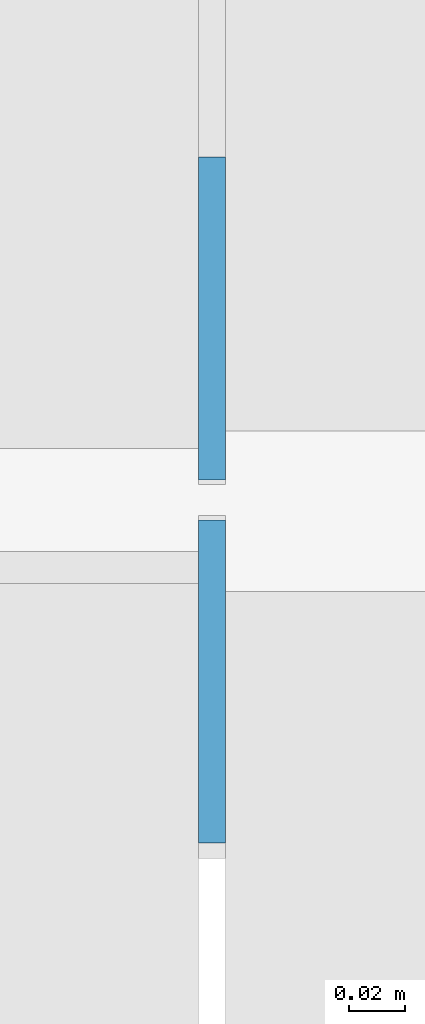
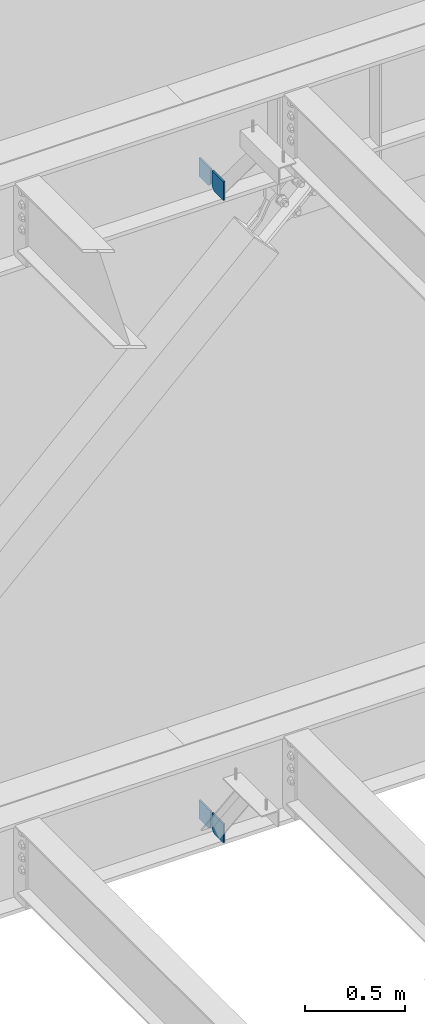
# One storey, part 577 of 1179: 4 columns, 2 elements without a shape of their own.
"""IFC2X3 building model written with IfcOpenShell, lengths in millimetres."""

import ifcopenshell
import ifcopenshell.guid

model = None  # the IFC model being written
_history = None  # IfcOwnerHistory: only IFC2X3 demands one
_inside = {}  # id of a spatial element -> (the spatial element, [elements in it])
_under = {}  # id of a project, library or spatial element -> (it, [spatial elements below it])
_declared = {}  # id of a project -> (the project, [libraries it declares])
_typed = {}  # id of a type object -> (the type object, [elements of that type])
_made_of = {}  # id of a material, layer set ... -> (it, [elements and type objects made of it])


def new_model(schema):
    """Start an empty IFC model of exactly this schema.

    Asked for "IFC4X3", IfcOpenShell would pick the latest addendum, in which some entities
    have other attributes; the version numbers below select the first issue.
    IFC2X3 requires an IfcOwnerHistory on every rooted entity: one is made here for all.
    """
    global model, _history
    if schema == "IFC4X3":
        model = ifcopenshell.file(schema_version=(4, 3, 0, 0))
    else:
        model = ifcopenshell.file(schema=schema)
    _inside.clear()
    _under.clear()
    _declared.clear()
    _typed.clear()
    _made_of.clear()
    _history = None
    if model.schema == "IFC2X3":
        org = make("IfcOrganization", Name="unknown")
        user = make(
            "IfcPersonAndOrganization",
            ThePerson=make("IfcPerson", FamilyName="unknown"),
            TheOrganization=org,
        )
        app = make(
            "IfcApplication",
            ApplicationDeveloper=org,
            Version="unknown",
            ApplicationFullName="unknown",
            ApplicationIdentifier="unknown",
        )
        _history = make(
            "IfcOwnerHistory",
            OwningUser=user,
            OwningApplication=app,
            ChangeAction="ADDED",
            CreationDate=0,
        )
    return model


def make(cls, **values):
    """One entity of the class cls with the attributes given. An attribute that is None is left unset."""
    return model.create_entity(
        cls, **{name: value for name, value in values.items() if value is not None}
    )


def rooted(cls, **values):
    """An entity with a GlobalId (a new one), such as an element, a storey or a relation."""
    return make(cls, GlobalId=ifcopenshell.guid.new(), OwnerHistory=_history, **values)


def si_unit(unit_type, name, prefix=None):
    """IfcSIUnit, for example si_unit("LENGTHUNIT", "METRE", prefix="MILLI")."""
    return make("IfcSIUnit", UnitType=unit_type, Prefix=prefix, Name=name)


def assignment(units):
    """IfcUnitAssignment: the units of a project."""
    return None if units is None else make("IfcUnitAssignment", Units=units)


def point(xyz):
    """IfcCartesianPoint."""
    return None if xyz is None else make("IfcCartesianPoint", Coordinates=xyz)


def direction(xyz):
    """IfcDirection."""
    return None if xyz is None else make("IfcDirection", DirectionRatios=xyz)


def frame(location, z_axis=None, x_axis=None):
    """IfcAxis2Placement3D, a coordinate frame: its origin and axes. An axis left out is left unset."""
    return make(
        "IfcAxis2Placement3D",
        Location=point(location),
        Axis=direction(z_axis),
        RefDirection=direction(x_axis),
    )


def origin_with_axes():
    """The frame at (0, 0, 0) with the z axis (0, 0, 1) and the x axis (1, 0, 0) written out."""
    return frame((0.0, 0.0, 0.0), z_axis=(0.0, 0.0, 1.0), x_axis=(1.0, 0.0, 0.0))


def place(relative_to, where):
    """IfcLocalPlacement: puts the frame where relative to a parent placement (None: the world)."""
    return make(
        "IfcLocalPlacement", PlacementRelTo=relative_to, RelativePlacement=where
    )


def context(
    kind, dimensions, precision=None, world=None, true_north=None, identifier=None
):
    """IfcGeometricRepresentationContext, for example the 3D "Model" context."""
    return make(
        "IfcGeometricRepresentationContext",
        ContextIdentifier=identifier,
        ContextType=kind,
        CoordinateSpaceDimension=dimensions,
        Precision=precision,
        WorldCoordinateSystem=world,
        TrueNorth=true_north,
    )


def subcontext(parent, identifier, kind, view, scale=None):
    """IfcGeometricRepresentationSubContext, for example "Body" below "Model"."""
    return make(
        "IfcGeometricRepresentationSubContext",
        ContextIdentifier=identifier,
        ContextType=kind,
        ParentContext=parent,
        TargetScale=scale,
        TargetView=view,
    )


def project(units=None, contexts=None):
    """IfcProject with its units and contexts."""
    return rooted(
        "IfcProject",
        Name="project",
        RepresentationContexts=contexts,
        UnitsInContext=assignment(units),
    )


def spatial(cls, under=None, at=None, **own):
    """A site, building, storey or space (cls), placed at a placement, below another one or the project."""
    s = rooted(cls, ObjectPlacement=at, **own)
    if under is not None:
        _under.setdefault(under.id(), (under, []))[1].append(s)
    return s


def faces_of(points, faces, orient=None, outer=None):
    """IfcFace entities. A face is a list of loops; a loop is a list of indices into points, from 0.

    orient and outer hold one flag for each loop. By default every Orientation is true, the
    first loop of a face is its IfcFaceOuterBound and the others are IfcFaceBound.
    """
    made = []
    for i, loops in enumerate(faces):
        bounds = []
        for j, loop in enumerate(loops):
            is_outer = j == 0 if outer is None else outer[i][j]
            bounds.append(
                make(
                    "IfcFaceOuterBound" if is_outer else "IfcFaceBound",
                    Bound=make("IfcPolyLoop", Polygon=[points[k] for k in loop]),
                    Orientation=True if orient is None else orient[i][j],
                )
            )
        made.append(make("IfcFace", Bounds=bounds))
    return made


def faceted_brep(points, faces, orient=None, outer=None, voids=None):
    """IfcFacetedBrep: a solid bounded by flat faces; with voids (closed shells), ...WithVoids."""
    shared = [point(p) for p in points]
    hull = make("IfcClosedShell", CfsFaces=faces_of(shared, faces, orient, outer))
    if voids is None:
        return make("IfcFacetedBrep", Outer=hull)
    return make(
        "IfcFacetedBrepWithVoids",
        Outer=hull,
        Voids=[
            make(cls, CfsFaces=faces_of(shared, fs, o, b)) for cls, fs, o, b in voids
        ],
    )


def shape(context_of_items, identifier, shape_type, items):
    """IfcShapeRepresentation: the items that make up one representation, for example the "Body"."""
    return make(
        "IfcShapeRepresentation",
        ContextOfItems=context_of_items,
        RepresentationIdentifier=identifier,
        RepresentationType=shape_type,
        Items=items,
    )


def material(Name=None, Category=None):
    """IfcMaterial."""
    return make("IfcMaterial", Name=Name, Category=Category)


def made_of(thing, what):
    """Note that an element or type object is made of a material, layer set ...; save() writes the relation."""
    if what is not None:
        _made_of.setdefault(what.id(), (what, []))[1].append(thing)
    return thing


def type_object(cls, material=None, **own):
    """A type object (cls), such as IfcWallType, which elements share."""
    return made_of(rooted(cls, **own), material)


def element(
    cls,
    number,
    at=None,
    inside=None,
    cuts=None,
    type_object=None,
    material=None,
    context=None,
    identifier="Body",
    shape_type=None,
    held_by="IfcProductDefinitionShape",
    body=None,
    shapes=None,
    **own,
):
    """One element of the class cls, such as IfcWall. Its Tag is "e" and its number.

    at: its placement. inside: the storey or other place that contains it. cuts: it is an
    opening in that element (IfcRelVoidsElement). A single representation is given by context,
    identifier, shape_type and body (its items); several are given by shapes. held_by: the class
    of the entity that holds the representations. save() writes the other relations.
    """
    e = rooted(cls, Tag="e%d" % number, ObjectPlacement=at, **own)
    if body is not None:
        shapes = [shape(context, identifier, shape_type, body)]
    if shapes is not None:
        e.Representation = make(held_by, Representations=shapes)
    if inside is not None:
        _inside.setdefault(inside.id(), (inside, []))[1].append(e)
    if cuts is not None:
        rooted(
            "IfcRelVoidsElement", RelatingBuildingElement=cuts, RelatedOpeningElement=e
        )
    if type_object is not None:
        _typed.setdefault(type_object.id(), (type_object, []))[1].append(e)
    return made_of(e, material)


def aggregate(whole, parts):
    """IfcRelAggregates: a whole, such as a stair, and the parts it consists of."""
    return rooted("IfcRelAggregates", RelatingObject=whole, RelatedObjects=parts)


def save(model, path):
    """Write the relations noted so far, then the file.

    IfcRelAggregates (storeys below a building ...), IfcRelContainedInSpatialStructure (elements
    in a storey), IfcRelDefinesByType, IfcRelAssociatesMaterial and IfcRelDeclares: one each for
    every whole, place, type object, material and project.
    """
    for whole, parts in _under.values():
        aggregate(whole, parts)
    for where, things in _inside.values():
        rooted(
            "IfcRelContainedInSpatialStructure",
            RelatedElements=things,
            RelatingStructure=where,
        )
    for kind, things in _typed.values():
        rooted("IfcRelDefinesByType", RelatedObjects=things, RelatingType=kind)
    for what, things in _made_of.values():
        rooted("IfcRelAssociatesMaterial", RelatedObjects=things, RelatingMaterial=what)
    for by, libraries in _declared.values():
        rooted("IfcRelDeclares", RelatingContext=by, RelatedDefinitions=libraries)
    model.write(path)


model = new_model("IFC2X3")

# Units and contexts
model_context = context("Model", 3, precision=1e-05, world=origin_with_axes())
body_context = subcontext(model_context, "Body", "Model", "MODEL_VIEW")
ifc_project = project(units=[si_unit("LENGTHUNIT", "METRE", prefix="MILLI"), si_unit("AREAUNIT", "SQUARE_METRE"), si_unit("VOLUMEUNIT", "CUBIC_METRE"), si_unit("MASSUNIT", "GRAM", prefix="KILO"), si_unit("TIMEUNIT", "SECOND"), si_unit("PLANEANGLEUNIT", "RADIAN"), si_unit("SOLIDANGLEUNIT", "STERADIAN"), si_unit("THERMODYNAMICTEMPERATUREUNIT", "DEGREE_CELSIUS"), si_unit("LUMINOUSINTENSITYUNIT", "LUMEN")], contexts=[model_context])

# Site, building, storey
site_placement = place(None, origin_with_axes())
site = spatial("IfcSite", under=ifc_project, at=site_placement, CompositionType="ELEMENT")
building_placement = place(site_placement, origin_with_axes())
building = spatial("IfcBuilding", under=site, at=building_placement, Name="Undefined", CompositionType="ELEMENT")
storey_placement = place(building_placement, origin_with_axes())
storey = spatial("IfcBuildingStorey", under=building, at=storey_placement, Name="Undefined", CompositionType="ELEMENT", Elevation=0.0)

# Assembly, columns
assembly_1_placement = place(storey_placement, origin_with_axes())
assembly_1 = element("IfcElementAssembly", 1, at=assembly_1_placement, inside=storey, Name="BEAM", AssemblyPlace="NOTDEFINED", PredefinedType="RIGID_FRAME")
ifc_material = material(Name="STEEL/A36")
column_type = type_object("IfcColumnType", PredefinedType="NOTDEFINED")
column_1_placement = place(assembly_1_placement, frame((11460.1625, 41263.09375, 7488.2375), z_axis=(0.0, -1.0, 0.0), x_axis=(0.0, 0.0, 1.0)))
column_1 = element("IfcColumn", 2, at=column_1_placement, type_object=column_type, material=ifc_material, Name="PLATE", context=body_context, shape_type="Brep", body=[
    faceted_brep([(22.2250000000004, 4.76250000000073, 57.1500000000015), (0.0, 4.76250000000073, 34.9249999999993), (0.0, -4.76250000000073, 34.9249999999993), (22.2250000000004, -4.76250000000073, 57.1500000000015), (114.300000000001, 4.76250000000073, 57.1500000000015), (114.300000000001, 4.76250000000073, -57.1500000000015), (0.0, 4.76250000000073, -57.1500000000015), (114.300000000001, -4.76250000000073, 57.1500000000015), (0.0, -4.76250000000073, -57.1500000000015), (114.300000000001, -4.76250000000073, -57.1500000000015)], [[[0, 1, 2, 3]], [[4, 5, 6, 1, 0]], [[7, 4, 0, 3]], [[8, 9, 7, 3, 2]], [[8, 6, 5, 9]], [[7, 9, 5, 4]], [[6, 8, 2, 1]]]),
])
column_2_placement = place(assembly_1_placement, frame((11460.1625, 41134.50625, 7488.2375), z_axis=(0.0, 1.0, 0.0), x_axis=(0.0, 0.0, 1.0)))
column_2 = element("IfcColumn", 3, at=column_2_placement, type_object=column_type, material=ifc_material, Name="PLATE", context=body_context, shape_type="Brep", body=[
    faceted_brep([(22.2250000000004, 4.76250000000073, 57.1500000000015), (0.0, 4.76250000000073, 34.9249999999993), (0.0, -4.76250000000073, 34.9249999999993), (22.2250000000004, -4.76250000000073, 57.1500000000015), (114.300000000001, 4.76250000000073, 57.1500000000015), (114.300000000001, 4.76250000000073, -57.1500000000015), (0.0, 4.76250000000073, -57.1500000000015), (114.300000000001, -4.76250000000073, 57.1500000000015), (0.0, -4.76250000000073, -57.1500000000015), (114.300000000001, -4.76250000000073, -57.1500000000015)], [[[0, 1, 2, 3]], [[4, 5, 6, 1, 0]], [[7, 4, 0, 3]], [[8, 9, 7, 3, 2]], [[8, 6, 5, 9]], [[7, 9, 5, 4]], [[6, 8, 2, 1]]]),
])
aggregate(assembly_1, [column_1, column_2])

assembly_2_placement = place(storey_placement, origin_with_axes())
assembly_2 = element("IfcElementAssembly", 4, at=assembly_2_placement, inside=storey, Name="BEAM", AssemblyPlace="NOTDEFINED", PredefinedType="RIGID_FRAME")
column_3_placement = place(assembly_2_placement, frame((11460.16275, 41263.093625, 3576.6375), z_axis=(0.0, -1.0, 0.0), x_axis=(0.0, 0.0, 1.0)))
column_3 = element("IfcColumn", 5, at=column_3_placement, type_object=column_type, material=ifc_material, Name="PLATE", context=body_context, shape_type="Brep", body=[
    faceted_brep([(19.0500000000002, 4.76250000000073, 57.1500000000015), (0.0, 4.76250000000073, 38.0999999999985), (0.0, -4.76250000000073, 38.0999999999985), (19.0500000000002, -4.76250000000073, 57.1500000000015), (114.300000000001, 4.76250000000073, 57.1500000000015), (114.300000000001, 4.76250000000073, -57.1500000000015), (0.0, 4.76250000000073, -57.1500000000015), (114.300000000001, -4.76250000000073, 57.1500000000015), (0.0, -4.76250000000073, -57.1500000000015), (114.300000000001, -4.76250000000073, -57.1500000000015)], [[[0, 1, 2, 3]], [[4, 5, 6, 1, 0]], [[7, 4, 0, 3]], [[8, 9, 7, 3, 2]], [[8, 6, 5, 9]], [[7, 9, 5, 4]], [[6, 8, 2, 1]]]),
])
column_4_placement = place(assembly_2_placement, frame((11460.16275, 41134.506125, 3576.6375), z_axis=(0.0, 1.0, 0.0), x_axis=(0.0, 0.0, 1.0)))
column_4 = element("IfcColumn", 6, at=column_4_placement, type_object=column_type, material=ifc_material, Name="PLATE", context=body_context, shape_type="Brep", body=[
    faceted_brep([(19.0500000000002, 4.76250000000073, 57.1500000000015), (0.0, 4.76250000000073, 38.0999999999985), (0.0, -4.76250000000073, 38.0999999999985), (19.0500000000002, -4.76250000000073, 57.1500000000015), (114.300000000001, 4.76250000000073, 57.1500000000015), (114.300000000001, 4.76250000000073, -57.1500000000015), (0.0, 4.76250000000073, -57.1500000000015), (114.300000000001, -4.76250000000073, 57.1500000000015), (0.0, -4.76250000000073, -57.1500000000015), (114.300000000001, -4.76250000000073, -57.1500000000015)], [[[0, 1, 2, 3]], [[4, 5, 6, 1, 0]], [[7, 4, 0, 3]], [[8, 9, 7, 3, 2]], [[8, 6, 5, 9]], [[7, 9, 5, 4]], [[6, 8, 2, 1]]]),
])
aggregate(assembly_2, [column_3, column_4])

save(model, "model.ifc")
